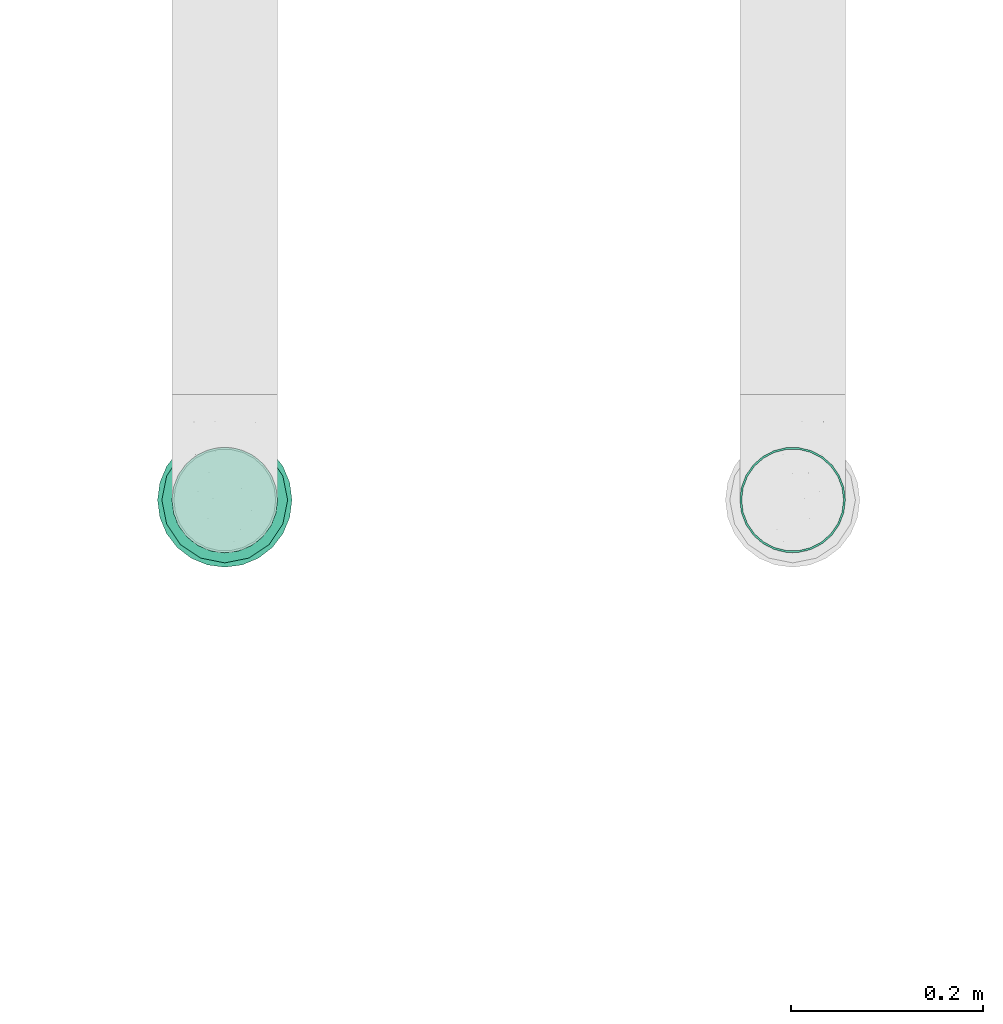
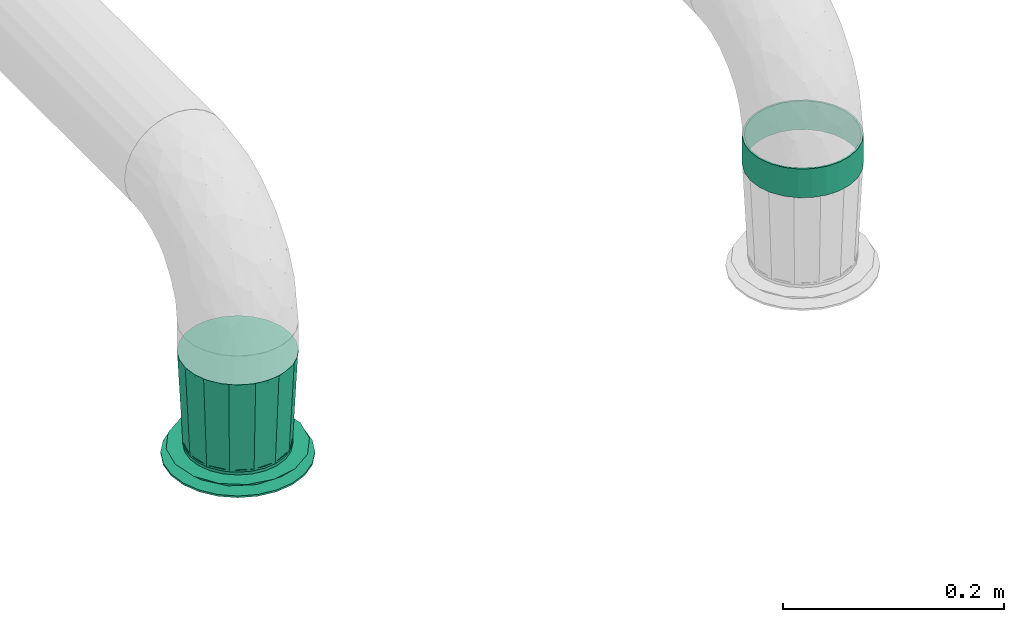
# One storey, part 69 of 103: 1 flow fitting, 1 flow segment, 1 flow terminal.
"""IFC2X3 building model written with IfcOpenShell, lengths in millimetres."""

from ifc_helpers import new_model, entity, si_unit, converted_unit, derived_unit, direction, frame, origin_with_axes, origin_2d_with_axis, place, context, subcontext, project, spatial, hollow_circle, extrude, open_shell, surface_model, source, transform, mapped, material, layer, layer_set, layer_usage, type_object, element, save


model = new_model("IFC2X3")

# Units and contexts
model_context = context("Model", 3, precision=1e-05, world=origin_with_axes(), true_north=direction((0.0, 1.0)))
body_context = subcontext(model_context, "Body", "Model", "MODEL_VIEW")
ifc_project = project(units=[si_unit("AREAUNIT", "SQUARE_METRE"), si_unit("VOLUMEUNIT", "CUBIC_METRE", prefix="DECI"), si_unit("TIMEUNIT", "SECOND"), si_unit("THERMODYNAMICTEMPERATUREUNIT", "DEGREE_CELSIUS"), si_unit("PRESSUREUNIT", "PASCAL"), si_unit("MASSUNIT", "GRAM", prefix="KILO"), si_unit("LENGTHUNIT", "METRE", prefix="MILLI"), si_unit("POWERUNIT", "WATT"), si_unit("ELECTRICCURRENTUNIT", "AMPERE"), si_unit("ELECTRICVOLTAGEUNIT", "VOLT"), derived_unit("VOLUMETRICFLOWRATEUNIT", [(si_unit("VOLUMEUNIT", "CUBIC_METRE", prefix="DECI"), 1), (si_unit("TIMEUNIT", "SECOND"), -1)]), derived_unit("LINEARVELOCITYUNIT", [(si_unit("LENGTHUNIT", "METRE"), 1), (si_unit("TIMEUNIT", "SECOND"), -1)]), derived_unit("MASSDENSITYUNIT", [(si_unit("MASSUNIT", "GRAM", prefix="KILO"), 1), (si_unit("VOLUMEUNIT", "CUBIC_METRE"), -1)]), converted_unit("PLANEANGLEUNIT", "DEGREE", entity("IfcRatioMeasure", 0.01745), si_unit("PLANEANGLEUNIT", "RADIAN"), dimensions=[0, 0, 0, 0, 0, 0, 0])], contexts=[model_context])

# Site, building, storey
site_placement = place(None, origin_with_axes())
site = spatial("IfcSite", under=ifc_project, at=site_placement, CompositionType="ELEMENT")
building_placement = place(site_placement, origin_with_axes())
building = spatial("IfcBuilding", under=site, at=building_placement, Name="mc-building", CompositionType="ELEMENT")
storey_placement = place(building_placement, frame((0.0, 0.0, 5900.0), z_axis=(0.0, 0.0, 1.0), x_axis=(1.0, 0.0, 0.0)))
storey = spatial("IfcBuildingStorey", under=building, at=storey_placement, Name="3. Korrus", CompositionType="ELEMENT", Elevation=5900.0)

# Flow terminal
air_terminal_type = type_object("IfcAirTerminalType", Name="100", PredefinedType="NOTDEFINED")
shared_shape_1 = source(origin_with_axes(), body_context, "Body", "SurfaceModel", [
    surface_model("IfcShellBasedSurfaceModel", [(11.2, 18.11733, -67.61481), (11.2, -18.11733, -67.61481), (11.2, 0.0, -70.0), (11.2, 67.61481, -18.11733), (11.2, 35.0, -60.62178), (11.2, 49.49747, -49.49747), (11.2, 60.62178, -35.0), (11.2, -67.61481, 18.11733), (11.2, -49.49747, -49.49747), (11.2, -67.61481, -18.11733), (11.2, -35.0, -60.62178), (11.2, -60.62178, -35.0), (11.2, -70.0, 0.0), (11.2, 18.11733, 67.61481), (11.2, 70.0, 0.0), (11.2, 67.61481, 18.11733), (11.2, 49.49747, 49.49747), (11.2, 60.62178, 35.0), (11.2, 35.0, 60.62178), (11.2, -49.49747, 49.49747), (11.2, -60.62178, 35.0), (11.2, -35.0, 60.62178), (11.2, -18.11733, 67.61481), (11.2, 0.0, 70.0), (9.2, 18.11733, 67.61481), (9.2, -67.61481, 18.11733), (9.2, 0.0, 70.0), (9.2, 49.49747, 49.49747), (9.2, 35.0, 60.62178), (9.2, 60.62178, 35.0), (9.2, 67.61481, 18.11733), (9.2, -35.0, 60.62178), (9.2, -49.49747, 49.49747), (9.2, -18.11733, 67.61481), (9.2, -60.62178, 35.0), (9.2, -67.61481, -18.11733), (9.2, -70.0, 0.0), (9.2, 67.61481, -18.11733), (9.2, 18.11733, -67.61481), (9.2, 49.49747, -49.49747), (9.2, 60.62178, -35.0), (9.2, 35.0, -60.62178), (9.2, -18.11733, -67.61481), (9.2, -49.49747, -49.49747), (9.2, -60.62178, -35.0), (9.2, -35.0, -60.62178), (9.2, 0.0, -70.0), (9.2, 70.0, 0.0), (9.2, 32.75, 0.0), (9.2, -16.375, 28.36233), (9.2, -28.36233, 16.375), (9.2, 16.375, 28.36233), (9.2, 0.0, 32.75), (9.2, 28.36233, 16.375), (9.2, -32.75, 0.0), (9.2, -16.375, -28.36233), (9.2, 16.375, -28.36233), (9.2, 0.0, -32.75), (9.2, 28.36233, -16.375), (9.2, -28.36233, -16.375), (6.2, -21.19625, -15.39997), (6.2, -21.19625, 15.39997), (6.2, 8.09625, 24.91768), (6.2, -8.09625, 24.91768), (6.2, -26.2, 0.0), (6.2, 21.19625, 15.39997), (6.2, -8.09625, -24.91768), (6.2, 21.19625, -15.39997), (6.2, 8.09625, -24.91768), (6.2, 26.2, 0.0), (9.2, 31.06579, -6.28555), (6.2, 23.69812, -7.69999), (6.2, -14.64625, -20.15883), (9.2, -22.36867, -22.36867), (6.2, -23.69812, -7.69999), (9.2, -31.06579, -6.28555), (6.2, 14.64625, -20.15883), (9.2, 8.1875, -30.55617), (6.2, 0.0, -24.91768), (9.2, 22.36867, -22.36867), (9.2, -8.1875, -30.55617), (9.2, -31.06579, 6.28555), (6.2, -23.69812, 7.69999), (6.2, 14.64625, 20.15883), (9.2, 22.36867, 22.36867), (6.2, 23.69812, 7.69999), (9.2, 31.06579, 6.28555), (6.2, -14.64625, 20.15883), (9.2, -8.1875, 30.55617), (6.2, 0.0, 24.91768), (9.2, -22.36867, 22.36867), (9.2, 8.1875, 30.55617), (6.2, -13.11761, 57.472), (6.2, -36.75472, 46.08897), (6.2, -53.11211, 25.57744), (6.2, 36.75472, 46.08897), (6.2, -58.95, 0.0), (6.2, 13.11761, 57.472), (6.2, 53.11211, 25.57744), (6.2, -53.11211, -25.57744), (6.2, -36.75472, -46.08897), (6.2, -13.11761, -57.472), (6.2, 58.95, 0.0), (6.2, 53.11211, -25.57744), (6.2, 13.11761, -57.472), (6.2, 36.75472, -46.08897), (0.0, -60.51411, 25.06576), (0.0, 0.0, 65.5), (0.0, 25.06576, 60.51411), (0.0, 46.3155, 46.3155), (0.0, 60.51411, 25.06576), (0.0, -46.3155, 46.3155), (0.0, -25.06576, 60.51411), (0.0, 0.0, -65.5), (0.0, -65.5, 0.0), (0.0, 65.5, 0.0), (0.0, 60.51411, -25.06576), (0.0, 46.3155, -46.3155), (0.0, 25.06576, -60.51411), (0.0, -46.3155, -46.3155), (0.0, -60.51411, -25.06576), (0.0, -25.06576, -60.51411), (6.2, 56.03105, -12.78872), (0.0, 53.4148, -35.69063), (0.0, 35.69063, -53.4148), (6.2, 24.93616, -51.78048), (0.0, -12.53288, -63.00706), (6.2, 0.0, -57.472), (0.0, -35.69063, -53.4148), (0.0, 63.00706, -12.53288), (6.2, 44.93342, -35.83321), (6.2, -24.93616, -51.78048), (6.2, -44.93342, -35.83321), (0.0, -53.4148, -35.69063), (0.0, 12.53288, -63.00706), (6.2, -56.03105, -12.78872), (0.0, -63.00706, -12.53288), (6.2, -56.03105, 12.78872), (0.0, -53.4148, 35.69063), (0.0, -35.69063, 53.4148), (6.2, -24.93616, 51.78048), (0.0, 12.53288, 63.00706), (6.2, 0.0, 57.472), (0.0, 35.69063, 53.4148), (0.0, -63.00706, 12.53288), (6.2, -44.93342, 35.83321), (6.2, 24.93616, 51.78048), (6.2, 44.93342, 35.83321), (0.0, 53.4148, 35.69063), (0.0, -12.53288, 63.00706), (6.2, 56.03105, 12.78872), (0.0, 63.00706, 12.53288), (-3.1, 12.94095, 48.29629), (-3.1, -35.35534, 35.35534), (-3.1, 0.0, 50.0), (-3.1, 35.35534, 35.35534), (-3.1, 25.0, 43.30127), (-3.1, -43.30127, 25.0), (-3.1, 43.30127, 25.0), (-3.1, -48.29629, -12.94095), (-3.1, -12.94095, 48.29629), (-3.1, -25.0, 43.30127), (-3.1, -50.0, 0.0), (-3.1, -48.29629, 12.94095), (-3.1, 48.29629, 12.94095), (-3.1, 12.94095, -48.29629), (-3.1, 50.0, 0.0), (-3.1, 48.29629, -12.94095), (-3.1, 35.35534, -35.35534), (-3.1, 43.30127, -25.0), (-3.1, 25.0, -43.30127), (-3.1, 0.0, -50.0), (-3.1, -35.35534, -35.35534), (-3.1, -43.30127, -25.0), (-3.1, -25.0, -43.30127), (-3.1, -12.94095, -48.29629), (0.0, 25.0, -43.30127), (0.0, 0.0, -50.0), (0.0, 12.94095, -48.29629), (0.0, 48.29629, -12.94095), (0.0, 35.35534, -35.35534), (0.0, -25.0, -43.30127), (0.0, 43.30127, -25.0), (0.0, -50.0, 0.0), (0.0, -12.94095, -48.29629), (0.0, -35.35534, -35.35534), (0.0, -48.29629, -12.94095), (0.0, -43.30127, -25.0), (0.0, 50.0, 0.0), (0.0, 43.30127, 25.0), (0.0, 12.94095, 48.29629), (0.0, 35.35534, 35.35534), (0.0, 25.0, 43.30127), (0.0, 0.0, 50.0), (0.0, -35.35534, 35.35534), (0.0, -43.30127, 25.0), (0.0, -48.29629, 12.94095), (0.0, -12.94095, 48.29629), (0.0, -25.0, 43.30127), (0.0, 48.29629, 12.94095), (-43.1, 0.0, 45.0), (-43.1, 11.64686, 43.46666), (-43.1, 22.5, 38.97115), (-43.1, -11.64686, 43.46666), (-43.1, 38.97115, 22.5), (-43.1, 43.46666, 11.64686), (-43.1, 31.81981, 31.81981), (-43.1, -22.5, 38.97115), (-43.1, -43.46666, 11.64686), (-43.1, -31.81981, 31.81981), (-43.1, -38.97115, 22.5), (-43.1, -45.0, 0.0), (-43.1, -43.46666, -11.64686), (-43.1, 45.0, 0.0), (-43.1, 43.46666, -11.64686), (-43.1, 38.97115, -22.5), (-43.1, 31.81981, -31.81981), (-43.1, 22.5, -38.97115), (-43.1, 11.64686, -43.46666), (-43.1, -31.81981, -31.81981), (-43.1, -38.97115, -22.5), (-43.1, -22.5, -38.97115), (-43.1, 0.0, -45.0), (-43.1, -11.64686, -43.46666), (-3.1, 22.5, -38.97115), (-3.1, 0.0, -45.0), (-3.1, 11.64686, -43.46666), (-3.1, 31.81981, -31.81981), (-3.1, -22.5, -38.97115), (-3.1, 38.97115, -22.5), (-3.1, 43.46666, -11.64686), (-3.1, 45.0, 0.0), (-3.1, -45.0, 0.0), (-3.1, -11.64686, -43.46666), (-3.1, -31.81981, -31.81981), (-3.1, -43.46666, -11.64686), (-3.1, -38.97115, -22.5), (-3.1, 0.0, 45.0), (-3.1, 43.46666, 11.64686), (-3.1, 38.97115, 22.5), (-3.1, 22.5, 38.97115), (-3.1, 31.81981, 31.81981), (-3.1, 11.64686, 43.46666), (-3.1, -11.64686, 43.46666), (-3.1, -43.46666, 11.64686), (-3.1, -31.81981, 31.81981), (-3.1, -38.97115, 22.5), (-3.1, -22.5, 38.97115)], [open_shell([[[0, 1, 2]], [[3, 0, 4]], [[5, 6, 3]], [[5, 3, 4]], [[7, 1, 0]], [[8, 7, 9]], [[10, 7, 8]], [[8, 9, 11]], [[12, 9, 7]], [[1, 7, 10]], [[7, 0, 3]], [[13, 14, 15]], [[16, 15, 17]], [[16, 18, 13]], [[16, 13, 15]], [[14, 13, 7]], [[7, 19, 20]], [[19, 7, 21]], [[7, 22, 21]], [[22, 7, 23]], [[7, 13, 23]], [[14, 7, 3]], [[24, 25, 26]], [[27, 24, 28]], [[27, 29, 30]], [[27, 30, 24]], [[25, 24, 30]], [[31, 25, 32]], [[25, 31, 33]], [[32, 25, 34]], [[33, 26, 25]], [[25, 35, 36]], [[25, 30, 37]], [[25, 37, 38]], [[39, 37, 40]], [[39, 41, 38]], [[39, 38, 37]], [[38, 42, 25]], [[35, 43, 44]], [[35, 25, 43]], [[45, 43, 25]], [[42, 45, 25]], [[38, 46, 42]], [[37, 30, 47]], [[35, 9, 36]], [[44, 11, 35]], [[10, 43, 45]], [[44, 43, 8]], [[1, 45, 42]], [[35, 11, 9]], [[9, 12, 36]], [[1, 10, 45]], [[8, 43, 10]], [[8, 11, 44]], [[2, 1, 42]], [[42, 46, 2]], [[38, 0, 46]], [[41, 4, 38]], [[6, 39, 40]], [[41, 39, 5]], [[3, 40, 37]], [[41, 5, 4]], [[4, 0, 38]], [[14, 3, 37]], [[6, 40, 3]], [[6, 5, 39]], [[47, 14, 37]], [[46, 0, 2]], [[30, 15, 47]], [[29, 17, 30]], [[18, 27, 28]], [[29, 27, 16]], [[13, 28, 24]], [[30, 17, 15]], [[15, 14, 47]], [[13, 18, 28]], [[16, 27, 18]], [[16, 17, 29]], [[23, 13, 24]], [[24, 26, 23]], [[33, 22, 26]], [[31, 21, 33]], [[20, 32, 34]], [[31, 32, 19]], [[7, 34, 25]], [[31, 19, 21]], [[21, 22, 33]], [[12, 7, 25]], [[20, 34, 7]], [[20, 19, 32]], [[36, 12, 25]], [[26, 22, 23]], [[48, 49, 50]], [[48, 51, 49]], [[49, 51, 52]], [[53, 51, 48]], [[48, 50, 54]], [[54, 55, 48]], [[56, 55, 57]], [[55, 58, 48]], [[58, 55, 56]], [[55, 54, 59]], [[60, 61, 62]], [[62, 61, 63]], [[64, 61, 60]], [[62, 65, 66]], [[67, 68, 65]], [[66, 60, 62]], [[65, 68, 66]], [[69, 67, 65]], [[69, 48, 70]], [[58, 71, 70]], [[72, 73, 60]], [[59, 74, 60]], [[75, 64, 74]], [[56, 68, 76]], [[72, 66, 55]], [[73, 72, 55]], [[68, 77, 78]], [[64, 75, 54]], [[59, 75, 74]], [[70, 71, 69]], [[67, 79, 76]], [[80, 55, 66]], [[68, 56, 77]], [[56, 76, 79]], [[79, 67, 58]], [[71, 58, 67]], [[80, 78, 57]], [[77, 57, 78]], [[66, 78, 80]], [[59, 60, 73]], [[64, 54, 81]], [[50, 82, 81]], [[83, 84, 65]], [[53, 85, 65]], [[86, 69, 85]], [[49, 63, 87]], [[83, 62, 51]], [[84, 83, 51]], [[63, 88, 89]], [[69, 86, 48]], [[53, 86, 85]], [[81, 82, 64]], [[61, 90, 87]], [[91, 51, 62]], [[63, 49, 88]], [[49, 87, 90]], [[90, 61, 50]], [[82, 50, 61]], [[91, 89, 52]], [[88, 52, 89]], [[62, 89, 91]], [[53, 65, 84]], [[92, 93, 94]], [[95, 94, 96]], [[97, 92, 95]], [[95, 92, 94]], [[96, 98, 95]], [[96, 99, 98]], [[99, 100, 101]], [[101, 102, 98]], [[102, 101, 103]], [[104, 105, 103]], [[101, 104, 103]], [[101, 98, 99]], [[106, 107, 108]], [[109, 110, 108]], [[106, 108, 110]], [[111, 112, 106]], [[106, 112, 107]], [[106, 113, 114]], [[106, 110, 113]], [[115, 116, 117]], [[117, 113, 110]], [[113, 117, 118]], [[114, 119, 120]], [[121, 119, 114]], [[121, 114, 113]], [[115, 117, 110]], [[103, 116, 122]], [[123, 116, 103]], [[124, 125, 118]], [[101, 126, 127]], [[100, 119, 128]], [[102, 122, 129]], [[103, 130, 123]], [[102, 129, 115]], [[113, 127, 126]], [[125, 124, 105]], [[130, 105, 117]], [[118, 125, 104]], [[124, 117, 105]], [[131, 100, 128]], [[119, 100, 132]], [[133, 99, 120]], [[134, 118, 104]], [[122, 116, 129]], [[127, 134, 104]], [[131, 121, 101]], [[99, 133, 132]], [[128, 121, 131]], [[130, 117, 123]], [[101, 121, 126]], [[99, 135, 120]], [[96, 136, 135]], [[136, 120, 135]], [[134, 127, 113]], [[133, 119, 132]], [[136, 96, 114]], [[94, 106, 137]], [[138, 106, 94]], [[139, 140, 112]], [[97, 141, 142]], [[95, 109, 143]], [[96, 137, 144]], [[94, 145, 138]], [[96, 144, 114]], [[107, 142, 141]], [[140, 139, 93]], [[145, 93, 111]], [[112, 140, 92]], [[139, 111, 93]], [[146, 95, 143]], [[109, 95, 147]], [[148, 98, 110]], [[149, 112, 92]], [[137, 106, 144]], [[142, 149, 92]], [[146, 108, 97]], [[98, 148, 147]], [[143, 108, 146]], [[145, 111, 138]], [[97, 108, 141]], [[98, 150, 110]], [[102, 151, 150]], [[151, 110, 150]], [[149, 142, 107]], [[148, 109, 147]], [[151, 102, 115]], [[152, 153, 154]], [[155, 152, 156]], [[157, 152, 158]], [[158, 152, 155]], [[158, 159, 157]], [[160, 153, 161]], [[160, 154, 153]], [[157, 162, 163]], [[153, 152, 157]], [[157, 159, 162]], [[158, 164, 159]], [[165, 166, 167]], [[168, 167, 169]], [[170, 165, 167]], [[170, 167, 168]], [[166, 165, 171]], [[159, 172, 173]], [[172, 159, 174]], [[174, 171, 175]], [[159, 164, 174]], [[166, 171, 174]], [[174, 164, 166]], [[176, 177, 178]], [[179, 176, 180]], [[176, 179, 181]], [[179, 180, 182]], [[179, 183, 181]], [[177, 181, 184]], [[177, 176, 181]], [[185, 186, 187]], [[186, 185, 181]], [[181, 183, 186]], [[183, 179, 188]], [[183, 188, 189]], [[190, 189, 191]], [[189, 190, 183]], [[190, 191, 192]], [[193, 194, 190]], [[183, 195, 196]], [[183, 190, 195]], [[194, 197, 198]], [[194, 195, 190]], [[197, 194, 193]], [[189, 188, 199]], [[164, 199, 166]], [[158, 189, 164]], [[192, 155, 156]], [[158, 155, 191]], [[190, 156, 152]], [[164, 189, 199]], [[199, 188, 166]], [[190, 192, 156]], [[191, 155, 192]], [[191, 189, 158]], [[193, 190, 152]], [[152, 154, 193]], [[160, 197, 154]], [[161, 198, 160]], [[195, 153, 157]], [[161, 153, 194]], [[196, 157, 163]], [[161, 194, 198]], [[198, 197, 160]], [[183, 196, 163]], [[195, 157, 196]], [[195, 194, 153]], [[162, 183, 163]], [[154, 197, 193]], [[159, 186, 162]], [[173, 187, 159]], [[181, 172, 174]], [[173, 172, 185]], [[184, 174, 175]], [[159, 187, 186]], [[186, 183, 162]], [[184, 181, 174]], [[185, 172, 181]], [[185, 187, 173]], [[177, 184, 175]], [[175, 171, 177]], [[165, 178, 171]], [[170, 176, 165]], [[182, 168, 169]], [[170, 168, 180]], [[179, 169, 167]], [[170, 180, 176]], [[176, 178, 165]], [[188, 179, 167]], [[182, 169, 179]], [[182, 180, 168]], [[166, 188, 167]], [[171, 178, 177]], [[200, 201, 202]], [[203, 200, 202]], [[204, 205, 202]], [[204, 202, 206]], [[203, 202, 205]], [[207, 208, 209]], [[207, 203, 205]], [[209, 208, 210]], [[211, 208, 212]], [[208, 207, 212]], [[207, 205, 212]], [[213, 214, 215]], [[205, 215, 212]], [[212, 216, 217]], [[216, 212, 215]], [[218, 219, 217]], [[212, 219, 220]], [[212, 217, 219]], [[221, 222, 223]], [[222, 221, 219]], [[218, 222, 219]], [[215, 205, 213]], [[224, 225, 226]], [[227, 228, 224]], [[229, 230, 231]], [[228, 227, 229]], [[229, 232, 228]], [[225, 228, 233]], [[225, 224, 228]], [[234, 235, 236]], [[235, 234, 228]], [[228, 232, 235]], [[232, 229, 231]], [[237, 238, 239]], [[240, 239, 241]], [[240, 242, 237]], [[240, 237, 239]], [[238, 237, 243]], [[244, 245, 246]], [[247, 244, 232]], [[244, 247, 245]], [[232, 238, 247]], [[238, 243, 247]], [[238, 232, 231]], [[205, 238, 213]], [[204, 239, 205]], [[240, 206, 202]], [[204, 206, 241]], [[242, 202, 201]], [[205, 239, 238]], [[238, 231, 213]], [[240, 202, 242]], [[241, 206, 240]], [[241, 239, 204]], [[201, 237, 242]], [[201, 200, 237]], [[243, 203, 207]], [[209, 247, 207]], [[246, 210, 208]], [[209, 210, 245]], [[244, 208, 211]], [[203, 243, 200]], [[207, 247, 243]], [[200, 243, 237]], [[209, 245, 247]], [[210, 246, 245]], [[244, 246, 208]], [[211, 232, 244]], [[212, 235, 211]], [[220, 236, 212]], [[228, 219, 221]], [[220, 219, 234]], [[233, 221, 223]], [[212, 236, 235]], [[235, 232, 211]], [[233, 228, 221]], [[234, 219, 228]], [[234, 236, 220]], [[225, 233, 223]], [[223, 222, 225]], [[226, 218, 217]], [[216, 224, 217]], [[229, 215, 214]], [[216, 215, 227]], [[230, 214, 213]], [[218, 226, 222]], [[217, 224, 226]], [[222, 226, 225]], [[216, 227, 224]], [[215, 229, 227]], [[230, 229, 214]], [[213, 231, 230]]])]),
])
flow_terminal_placement = place(storey_placement, frame((26302.64841, 8183.57591, 2100.0), z_axis=(0.0, 1.0, 0.0), x_axis=(0.0, 0.0, -1.0)))
element("IfcFlowTerminal", 1, at=flow_terminal_placement, inside=storey, type_object=air_terminal_type, Name="100", context=body_context, shape_type="MappedRepresentation", body=[
    mapped(shared_shape_1, transform((0.0, 0.0, 0.0), scale=1.0)),
])

# Flow segment
ifc_material = material(Name="FZ1")
ifc_layer = layer(ifc_material, 0.0)
ifc_layer_set = layer_set([ifc_layer], Name="FZ1")
ifc_layer_usage = layer_usage(ifc_layer_set, "AXIS1", "POSITIVE", 0.0)
duct_segment_type = type_object("IfcDuctSegmentType", Name="Safe", PredefinedType="RIGIDSEGMENT")
shared_shape_2 = source(origin_with_axes(), body_context, "Body", "SweptSolid", [
    extrude(hollow_circle(Radius=55.0, WallThickness=2.0, at=origin_2d_with_axis()), frame((0.0, 0.0, 0.0), z_axis=(1.0, 0.0, 0.0), x_axis=(0.0, 1.0, 0.0)), (0.0, 0.0, 1.0), 31.9),
])
flow_segment_placement = place(storey_placement, frame((26894.1474, 8183.57591, 2235.0), z_axis=(0.0, 1.0, 0.0), x_axis=(0.0, 0.0, -1.0)))
element("IfcFlowSegment", 2, at=flow_segment_placement, inside=storey, type_object=duct_segment_type, material=ifc_layer_usage, Name="Safe", context=body_context, shape_type="MappedRepresentation", body=[
    mapped(shared_shape_2, transform((0.0, 0.0, 0.0), scale=1.0)),
])

# Flow fitting
duct_fitting_type = type_object("IfcDuctFittingType", PredefinedType="TRANSITION")
shared_shape_3 = source(origin_with_axes(), body_context, "Body", "SurfaceModel", [
    surface_model("IfcShellBasedSurfaceModel", [(0.0, 12.94095, 48.29629), (0.0, -35.35534, 35.35534), (0.0, 0.0, 50.0), (0.0, 35.35534, 35.35534), (0.0, 25.0, 43.30127), (0.0, 43.30127, 25.0), (0.0, 48.29629, 12.94095), (0.0, -12.94095, 48.29629), (0.0, -25.0, 43.30127), (0.0, -48.29629, 12.94095), (0.0, -43.30127, 25.0), (0.0, -25.0, -43.30127), (0.0, -48.29629, -12.94095), (0.0, -50.0, 0.0), (0.0, 48.29629, -12.94095), (0.0, 12.94095, -48.29629), (0.0, 43.30127, -25.0), (0.0, 35.35534, -35.35534), (0.0, 25.0, -43.30127), (0.0, -35.35534, -35.35534), (0.0, -43.30127, -25.0), (0.0, -12.94095, -48.29629), (0.0, 0.0, -50.0), (0.0, 50.0, 0.0), (100.0, -55.0, 0.0), (100.0, -12.23865, 53.62104), (100.0, -34.29194, 43.00073), (100.0, 49.55329, -23.86361), (100.0, 12.23865, 53.62104), (100.0, 34.29194, 43.00073), (100.0, 55.0, 0.0), (100.0, 49.55329, 23.86361), (100.0, -49.55329, 23.86361), (100.0, 12.23865, -53.62104), (100.0, -49.55329, -23.86361), (100.0, -34.29194, -43.00073), (100.0, 34.29194, -43.00073), (100.0, -12.23865, -53.62104), (0.0, 11.12605, 48.7464), (0.0, -11.12605, 48.7464), (0.0, 31.17449, 39.09157), (0.0, -45.04844, -21.69419), (0.0, -45.04844, 21.69419), (0.0, -31.17449, 39.09157), (0.0, 45.04844, 21.69419), (0.0, 45.04844, -21.69419), (0.0, 31.17449, -39.09157), (0.0, -31.17449, -39.09157), (0.0, -11.12605, -48.7464), (0.0, 11.12605, -48.7464), (0.0, -47.52422, -10.84709), (100.0, -41.92261, -33.43217), (0.0, -38.11147, -30.39288), (100.0, 41.92261, -33.43217), (0.0, 38.11147, -30.39288), (0.0, -21.15027, -43.91899), (100.0, -23.2653, -48.31088), (100.0, -52.32388, -11.72483), (100.0, 0.0, -53.62104), (0.0, 0.0, -48.7464), (100.0, 23.2653, -48.31088), (0.0, 21.15027, -43.91899), (100.0, 52.32388, -11.72483), (0.0, 47.52422, -10.84709), (0.0, 47.52422, 10.84709), (100.0, 41.92261, 33.43217), (0.0, 38.11147, 30.39288), (100.0, -41.92261, 33.43217), (0.0, -38.11147, 30.39288), (0.0, 21.15027, 43.91899), (100.0, 23.2653, 48.31088), (100.0, 52.32388, 11.72483), (100.0, 0.0, 53.62104), (0.0, 0.0, 48.7464), (100.0, -23.2653, 48.31088), (0.0, -21.15027, 43.91899), (100.0, -52.32388, 11.72483), (0.0, -47.52422, 10.84709), (100.0, 27.5, -47.63139), (100.0, 0.0, -55.0), (100.0, 14.23505, -53.12592), (100.0, 38.89087, -38.89087), (100.0, -27.5, -47.63139), (100.0, 47.63139, -27.5), (100.0, 53.12592, -14.23505), (100.0, -14.23505, -53.12592), (100.0, -47.63139, -27.5), (100.0, -38.89087, -38.89087), (100.0, -53.12592, -14.23505), (100.0, 53.12592, 14.23505), (100.0, 47.63139, 27.5), (100.0, 27.5, 47.63139), (100.0, 38.89087, 38.89087), (100.0, 14.23505, 53.12592), (100.0, 0.0, 55.0), (100.0, -47.63139, 27.5), (100.0, -53.12592, 14.23505), (100.0, -27.5, 47.63139), (100.0, -38.89087, 38.89087), (100.0, -14.23505, 53.12592), (98.0, 0.0, 55.0), (98.0, 14.23505, 53.12592), (98.0, 27.5, 47.63139), (98.0, 38.89087, 38.89087), (98.0, 47.63139, 27.5), (98.0, -47.63139, 27.5), (98.0, 53.12592, -14.23505), (98.0, -27.5, 47.63139), (98.0, -14.23505, 53.12592), (98.0, -38.89087, 38.89087), (98.0, -55.0, 0.0), (98.0, -53.12592, 14.23505), (98.0, 53.12592, 14.23505), (98.0, 47.63139, -27.5), (98.0, -27.5, -47.63139), (98.0, 0.0, -55.0), (98.0, 38.89087, -38.89087), (98.0, 27.5, -47.63139), (98.0, 14.23505, -53.12592), (98.0, -47.63139, -27.5), (98.0, -38.89087, -38.89087), (98.0, -53.12592, -14.23505), (98.0, -14.23505, -53.12592), (98.0, 55.0, 0.0), (2.0, 12.94095, -48.29629), (2.0, 25.0, -43.30127), (2.0, 35.35534, -35.35534), (2.0, 43.30127, -25.0), (2.0, 48.29629, -12.94095), (2.0, 0.0, -50.0), (2.0, 50.0, 0.0), (2.0, -25.0, -43.30127), (2.0, -12.94095, -48.29629), (2.0, -35.35534, -35.35534), (2.0, -48.29629, -12.94095), (2.0, -43.30127, -25.0), (2.0, -48.29629, 12.94095), (2.0, 48.29629, 12.94095), (2.0, 43.30127, 25.0), (2.0, 35.35534, 35.35534), (2.0, -35.35534, 35.35534), (2.0, 12.94095, 48.29629), (2.0, 25.0, 43.30127), (2.0, 0.0, 50.0), (2.0, -43.30127, 25.0), (2.0, -50.0, 0.0), (2.0, -12.94095, 48.29629), (2.0, -25.0, 43.30127)], [open_shell([[[0, 1, 2]], [[3, 0, 4]], [[3, 5, 6]], [[0, 3, 1]], [[6, 1, 3]], [[7, 1, 8]], [[7, 2, 1]], [[1, 9, 10]], [[9, 1, 11]], [[12, 13, 9]], [[11, 1, 6]], [[6, 14, 11]], [[15, 14, 16]], [[17, 18, 15]], [[17, 15, 16]], [[11, 14, 15]], [[12, 19, 20]], [[19, 12, 11]], [[15, 21, 11]], [[12, 9, 11]], [[22, 21, 15]], [[14, 6, 23]], [[24, 25, 26]], [[25, 27, 28]], [[29, 28, 27]], [[27, 30, 31]], [[31, 29, 27]], [[24, 26, 32]], [[33, 24, 34]], [[33, 34, 35]], [[36, 27, 33]], [[33, 27, 24]], [[35, 37, 33]], [[24, 27, 25]], [[38, 23, 39]], [[40, 23, 38]], [[41, 42, 43]], [[41, 13, 42]], [[23, 43, 39]], [[40, 44, 23]], [[41, 23, 45]], [[41, 45, 46]], [[47, 41, 48]], [[49, 48, 41]], [[41, 46, 49]], [[23, 41, 43]], [[34, 50, 41]], [[47, 51, 52]], [[45, 27, 53]], [[36, 54, 53]], [[55, 48, 56]], [[34, 57, 50]], [[57, 13, 50]], [[13, 57, 24]], [[55, 35, 47]], [[35, 51, 47]], [[51, 41, 52]], [[58, 59, 49]], [[60, 61, 46]], [[37, 59, 58]], [[62, 63, 23]], [[35, 55, 56]], [[23, 30, 62]], [[53, 54, 45]], [[48, 37, 56]], [[33, 49, 61]], [[49, 33, 58]], [[54, 36, 46]], [[63, 27, 45]], [[34, 41, 51]], [[33, 61, 60]], [[48, 59, 37]], [[27, 63, 62]], [[46, 36, 60]], [[31, 64, 44]], [[40, 65, 66]], [[42, 32, 67]], [[26, 68, 67]], [[69, 38, 70]], [[31, 71, 64]], [[71, 23, 64]], [[23, 71, 30]], [[69, 29, 40]], [[29, 65, 40]], [[65, 44, 66]], [[72, 73, 39]], [[74, 75, 43]], [[28, 73, 72]], [[76, 77, 13]], [[29, 69, 70]], [[13, 24, 76]], [[67, 68, 42]], [[38, 28, 70]], [[25, 39, 75]], [[39, 25, 72]], [[68, 26, 43]], [[77, 32, 42]], [[31, 44, 65]], [[25, 75, 74]], [[38, 73, 28]], [[32, 77, 76]], [[43, 26, 74]], [[78, 79, 80]], [[81, 82, 78]], [[82, 83, 84]], [[81, 83, 82]], [[30, 82, 84]], [[79, 82, 85]], [[79, 78, 82]], [[82, 86, 87]], [[82, 30, 86]], [[24, 88, 86]], [[86, 30, 89]], [[90, 24, 89]], [[91, 90, 92]], [[91, 93, 94]], [[90, 91, 24]], [[94, 95, 91]], [[24, 95, 96]], [[24, 91, 95]], [[94, 97, 98]], [[98, 95, 94]], [[97, 94, 99]], [[89, 24, 86]], [[100, 101, 102]], [[100, 102, 103]], [[100, 104, 105]], [[104, 100, 103]], [[106, 105, 104]], [[100, 107, 108]], [[100, 109, 107]], [[105, 110, 111]], [[109, 100, 105]], [[105, 106, 110]], [[106, 104, 112]], [[106, 113, 110]], [[113, 114, 110]], [[115, 116, 117]], [[113, 116, 115]], [[117, 118, 115]], [[119, 114, 120]], [[121, 110, 119]], [[114, 115, 122]], [[119, 110, 114]], [[115, 114, 113]], [[123, 106, 112]], [[121, 88, 110]], [[119, 86, 121]], [[82, 120, 114]], [[119, 120, 87]], [[85, 114, 122]], [[121, 86, 88]], [[88, 24, 110]], [[85, 82, 114]], [[87, 120, 82]], [[87, 86, 119]], [[79, 85, 122]], [[122, 115, 79]], [[118, 80, 115]], [[117, 78, 118]], [[83, 116, 113]], [[117, 116, 81]], [[84, 113, 106]], [[117, 81, 78]], [[78, 80, 118]], [[30, 84, 106]], [[83, 113, 84]], [[83, 81, 116]], [[123, 30, 106]], [[115, 80, 79]], [[112, 89, 123]], [[104, 90, 112]], [[91, 103, 102]], [[104, 103, 92]], [[93, 102, 101]], [[112, 90, 89]], [[89, 30, 123]], [[93, 91, 102]], [[92, 103, 91]], [[92, 90, 104]], [[94, 93, 101]], [[101, 100, 94]], [[108, 99, 100]], [[107, 97, 108]], [[95, 109, 105]], [[107, 109, 98]], [[96, 105, 111]], [[107, 98, 97]], [[97, 99, 108]], [[24, 96, 111]], [[95, 105, 96]], [[95, 98, 109]], [[110, 24, 111]], [[100, 99, 94]], [[124, 125, 126]], [[124, 126, 127]], [[124, 128, 129]], [[128, 124, 127]], [[129, 128, 130]], [[129, 131, 132]], [[129, 130, 131]], [[133, 134, 135]], [[134, 133, 131]], [[131, 136, 134]], [[131, 130, 137]], [[137, 138, 139]], [[140, 137, 139]], [[140, 139, 141]], [[141, 139, 142]], [[140, 141, 143]], [[136, 140, 144]], [[145, 134, 136]], [[140, 146, 147]], [[131, 140, 136]], [[143, 146, 140]], [[131, 137, 140]], [[12, 134, 13]], [[20, 135, 12]], [[131, 19, 11]], [[20, 19, 133]], [[132, 11, 21]], [[12, 135, 134]], [[134, 145, 13]], [[132, 131, 11]], [[133, 19, 131]], [[133, 135, 20]], [[129, 132, 21]], [[21, 22, 129]], [[15, 124, 22]], [[18, 125, 15]], [[127, 17, 16]], [[18, 17, 126]], [[128, 16, 14]], [[18, 126, 125]], [[125, 124, 15]], [[130, 128, 14]], [[127, 16, 128]], [[127, 126, 17]], [[23, 130, 14]], [[22, 124, 129]], [[6, 137, 23]], [[5, 138, 6]], [[142, 3, 4]], [[5, 3, 139]], [[141, 4, 0]], [[6, 138, 137]], [[137, 130, 23]], [[141, 142, 4]], [[139, 3, 142]], [[139, 138, 5]], [[143, 141, 0]], [[0, 2, 143]], [[7, 146, 2]], [[8, 147, 7]], [[144, 1, 10]], [[8, 1, 140]], [[136, 10, 9]], [[8, 140, 147]], [[147, 146, 7]], [[145, 136, 9]], [[144, 10, 136]], [[144, 140, 1]], [[13, 145, 9]], [[2, 146, 143]]])]),
])
flow_fitting_placement = place(storey_placement, frame((26302.64841, 8183.57591, 2103.1), z_axis=(0.0, 1.0, 0.0), x_axis=(0.0, 0.0, 1.0)))
element("IfcFlowFitting", 3, at=flow_fitting_placement, inside=storey, type_object=duct_fitting_type, context=body_context, shape_type="MappedRepresentation", body=[
    mapped(shared_shape_3, transform((0.0, 0.0, 0.0), scale=1.0)),
])

save(model, "model.ifc")
